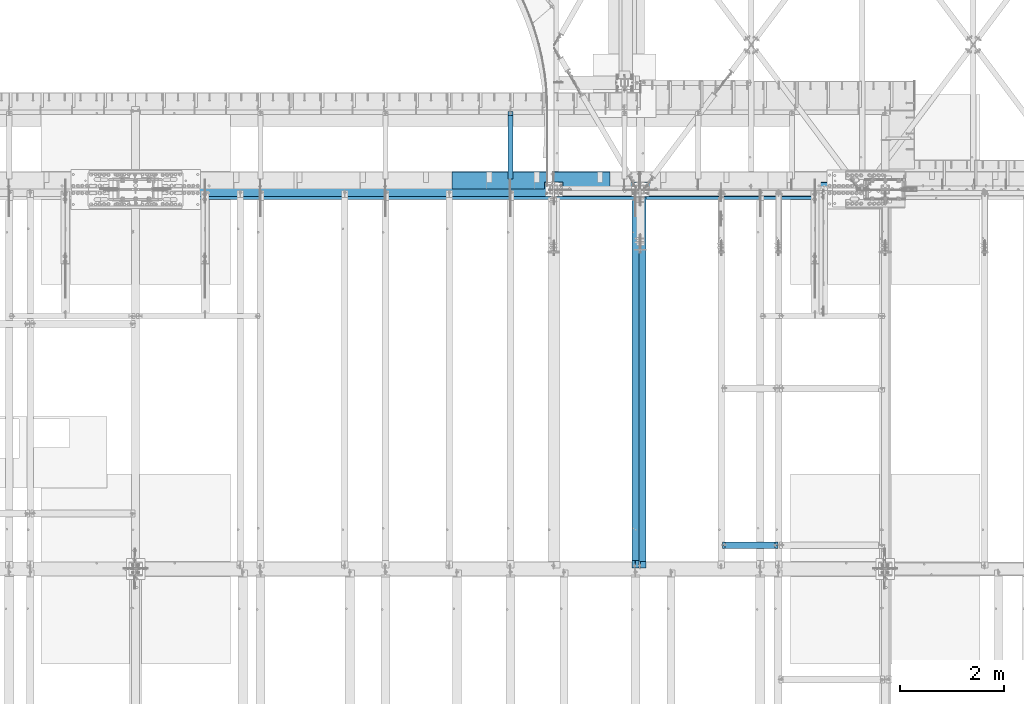
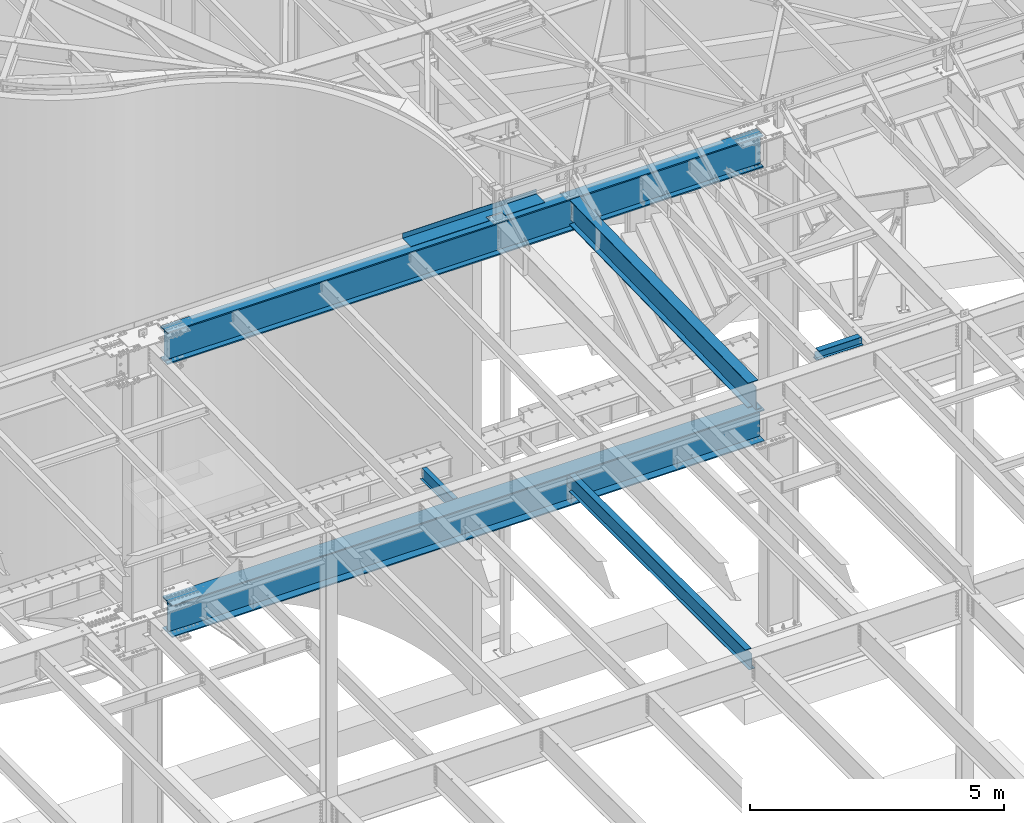
# One storey, part 1142 of 1763: 7 beams, 6 elements without a shape of their own.
"""IFC2X3 building model written with IfcOpenShell, lengths in millimetres."""

from ifc_helpers import new_model, si_unit, frame, origin_with_axes, place, context, subcontext, project, spatial, faceted_brep, material, type_object, element, aggregate, save


model = new_model("IFC2X3")

# Units and contexts
model_context = context("Model", 3, precision=1e-05, world=origin_with_axes())
body_context = subcontext(model_context, "Body", "Model", "MODEL_VIEW")
ifc_project = project(units=[si_unit("LENGTHUNIT", "METRE", prefix="MILLI"), si_unit("AREAUNIT", "SQUARE_METRE"), si_unit("VOLUMEUNIT", "CUBIC_METRE"), si_unit("MASSUNIT", "GRAM", prefix="KILO"), si_unit("TIMEUNIT", "SECOND"), si_unit("PLANEANGLEUNIT", "RADIAN"), si_unit("SOLIDANGLEUNIT", "STERADIAN"), si_unit("THERMODYNAMICTEMPERATUREUNIT", "DEGREE_CELSIUS"), si_unit("LUMINOUSINTENSITYUNIT", "LUMEN")], contexts=[model_context])

# Site, building, storey
site_placement = place(None, origin_with_axes())
site = spatial("IfcSite", under=ifc_project, at=site_placement, CompositionType="ELEMENT")
building_placement = place(site_placement, origin_with_axes())
building = spatial("IfcBuilding", under=site, at=building_placement, Name="Undefined", CompositionType="ELEMENT")
storey_placement = place(building_placement, origin_with_axes())
storey = spatial("IfcBuildingStorey", under=building, at=storey_placement, Name="Undefined", CompositionType="ELEMENT", Elevation=0.0)

# Assembly, beam
assembly_1_placement = place(storey_placement, origin_with_axes())
assembly_1 = element("IfcElementAssembly", 1, at=assembly_1_placement, inside=storey, Name="BEAM", AssemblyPlace="NOTDEFINED", PredefinedType="RIGID_FRAME")
ifc_material_1 = material(Name="STEEL/A992")
beam_type_1 = type_object("IfcBeamType", Name="W8X18", PredefinedType="NOTDEFINED")
beam_1_placement = place(assembly_1_placement, frame((-38107.8885203322, 45262.8, 11502.4228391437), z_axis=(0.0, 0.0, 1.0), x_axis=(1.0, 0.0, 0.0)))
beam_1 = element("IfcBeam", 2, at=beam_1_placement, type_object=beam_type_1, material=ifc_material_1, Name="BEAM", ObjectType="W8X18", context=body_context, shape_type="Brep", body=[
    faceted_brep([(1028.83123168945, 66.6750000000029, 95.25), (1028.83123168945, 3.17500000000291, 95.25), (73.0250000000015, 3.17500000000291, 95.25), (73.0250000000015, 66.6750000000029, 95.25), (15.8750019335712, -66.675000000032, -95.25), (15.8750019335712, -66.675000000032, -103.1875), (1085.98123168945, -66.6750000000029, -103.1875), (1085.98123168945, -66.6750000000029, -95.25), (15.875, -6.52466826784075, -103.1875), (15.875, 61.6753289071276, -103.1875), (15.8749980664215, 66.6749999999665, -103.1875), (1085.98123168945, 66.6750000000029, -103.1875), (1085.98123168945, 6.52466830228514, -103.1875), (1085.98123168945, -61.6753288726832, -103.1875), (15.8749980664215, 66.6749999999665, -95.25), (1085.98123168945, 66.6750000000029, -95.25), (15.875, 61.6746711106171, -95.25), (15.8749999079228, 3.17499999996653, -95.25), (1085.98123168945, 3.17500000000291, -95.25), (1085.98123168945, 6.52532609878836, -95.25), (65.1850797087827, -3.17500000000291, 72.1442315987078), (65.1850797087827, 3.17500000000291, 72.1442315987078), (60.3250001907363, 3.17500000000291, 71.1775016761203), (60.3250001907363, -3.17500000000291, 71.1775016761203), (69.3052561769364, -3.17500000000291, 74.8972454991854), (69.3052561769364, 3.17500000000291, 74.8972454991854), (72.0582700774103, -3.17500000000291, 79.017421967339), (72.0582700774103, 3.17500000000291, 79.017421967339), (73.0250000000015, -3.17500000000291, 83.8775014853854), (73.0250000000015, 3.17500000000291, 83.8775014853854), (1028.83123168945, 3.17500000000291, 83.8775014869243), (1029.79796161204, 3.17500000000291, 79.0174219688779), (1032.55097551252, 3.17500000000291, 74.8972455007242), (1036.67115198067, 3.17500000000291, 72.1442316002467), (1041.53123149872, 3.17500000000291, 71.1775016776592), (1085.98123168945, 3.17500000000291, 71.1775016776592), (1085.98123168945, 3.17500000000291, -91.3182885805927), (15.875, 3.17500000000291, -91.317762344921), (15.875, 3.17500000000291, 71.1775016761203), (15.875, -3.17500000000291, 71.1775016761203), (15.875, -6.52532606434397, -95.25), (15.87500009207, -3.17500000003201, -95.25), (15.875, -3.17500000000291, -91.3182885821243), (1085.98123168945, -3.17500000000291, -95.25), (1085.98123168945, -3.17500000000291, -91.3177623433876), (1085.98123168945, -3.17500000000291, 71.1775016776592), (1041.53123149872, -3.17500000000291, 71.1775016776592), (1036.67115198067, -3.17500000000291, 72.1442316002467), (1032.55097551252, -3.17500000000291, 74.8972455007242), (1029.79796161204, -3.17500000000291, 79.0174219688779), (1028.83123168945, -3.17500000000291, 83.8775014869243), (1028.83123168945, -3.17500000000291, 95.25), (73.0250000000015, -3.17500000000291, 95.25), (1028.83123168945, -66.6750000000029, 103.1875), (1028.83123168945, 66.6750000000029, 103.1875), (73.0250000000015, 66.6750000000029, 103.1875), (73.0250000000015, -66.6750000000029, 103.024323119123), (1028.83123168945, -66.6750000000029, 95.25), (73.0250000000015, -66.6750000000029, 95.25), (1085.98123168945, -61.6746710761727, -95.25)], [[[0, 1, 2, 3]], [[4, 5, 6, 7]], [[5, 8, 9, 10, 11, 12, 13, 6]], [[10, 14, 15, 11]], [[14, 16, 17, 18, 19, 15]], [[20, 21, 22, 23]], [[24, 25, 21, 20]], [[26, 27, 25, 24]], [[28, 29, 27, 26]], [[1, 30, 31, 32, 33, 34, 35, 36, 18, 17, 37, 38, 22, 21, 25, 27, 29, 2]], [[23, 22, 38, 39]], [[37, 17, 16, 14, 10, 9, 8, 5, 4, 40, 41, 42, 39, 38]], [[26, 24, 20, 23, 39, 42, 41, 43, 44, 45, 46, 47, 48, 49, 50, 51, 52, 28]], [[53, 54, 55, 56]], [[57, 53, 56, 58]], [[51, 57, 58, 52]], [[56, 55, 3, 2, 29, 28, 52, 58]], [[54, 0, 3, 55]], [[53, 57, 51, 50, 30, 1, 0, 54]], [[49, 31, 30, 50]], [[48, 32, 31, 49]], [[47, 33, 32, 48]], [[46, 34, 33, 47]], [[45, 35, 34, 46]], [[44, 43, 59, 7, 6, 13, 12, 11, 15, 19, 18, 36, 35, 45]], [[41, 40, 4, 7, 59, 43]]]),
])
aggregate(assembly_1, [beam_1])

assembly_2_placement = place(storey_placement, origin_with_axes())
assembly_2 = element("IfcElementAssembly", 3, at=assembly_2_placement, inside=storey, Name="BEAM", AssemblyPlace="NOTDEFINED", PredefinedType="RIGID_FRAME")
beam_type_2 = type_object("IfcBeamType", Name="W16X26", PredefinedType="NOTDEFINED")
beam_2_placement = place(assembly_2_placement, frame((-39767.3706070317, 44805.6, 4994.275), z_axis=(0.0, 0.0, 1.0), x_axis=(0.0, 1.0, 0.0)))
beam_2 = element("IfcBeam", 4, at=beam_2_placement, type_object=beam_type_2, material=ifc_material_1, Name="BEAM", ObjectType="W16X26", context=body_context, shape_type="Brep", body=[
    faceted_brep([(7104.06248869727, 3.17500000000291, -190.5), (7104.06248869734, 3.17487653380522, -200.025), (7104.06247902929, 69.8499999999985, -200.025), (7104.06247902929, 69.8499999999985, -190.5), (7294.5625, 3.17500000000291, -190.5), (7294.5625, 3.17490415680368, -200.025), (159.543749432261, 3.17500000000291, 190.5), (159.543749432261, 69.8499999999985, 190.5), (7104.0625, 69.8499999999985, 190.5), (7104.0625, 3.17500000000291, 190.5), (159.543749432261, -69.8499999999985, 200.025), (159.543749432261, 69.8499999999985, 200.025), (159.543749432261, 3.17500000000291, 180.715001487732), (159.543749432261, -3.17500000000291, 180.715001487732), (159.543749432261, -3.17500000000291, 190.5), (159.543749432261, -69.8499999999985, 190.5), (158.57701950967, 3.17500000000291, 175.854921969686), (158.57701950967, -3.17500000000291, 175.854921969686), (155.824005609196, 3.17500000000291, 171.734745501532), (155.824005609196, -3.17500000000291, 171.734745501532), (151.703829141043, 3.17500000000291, 168.981731601054), (151.703829141043, -3.17500000000291, 168.981731601054), (146.843749622996, 3.17500000000291, 168.015001678466), (146.843749622996, -3.17500000000291, 168.015001678466), (19.84375, 3.17500000000291, 168.015001678466), (19.84375, -3.17500000000291, 168.015001678466), (19.84375, 3.17500000000291, -190.5), (19.84375, 69.8499999999985, -190.5), (19.84375, 69.8499999999985, -200.025), (19.84375, -69.8499999999985, -200.025), (19.84375, -69.8499999999985, -190.5), (19.84375, -3.17500000000291, -190.5), (7294.5625, -69.8499999999985, -200.025), (7294.5625, -69.8499999999985, -190.5), (7294.5625, -3.17500000000291, -190.5), (7111.90242029122, -3.17500000000291, 156.541729922587), (7107.78224382307, -3.17500000000291, 159.294743823066), (7105.02922992258, -3.17500000000291, 163.414920291219), (7104.0625, -3.17500000000291, 168.274999809265), (7104.0625, -3.17500000000291, 190.5), (7294.5625, -3.17500000000291, 155.575), (7116.76249980927, -3.17500000000291, 155.575), (7104.0625, -69.8499999999985, 190.5), (7104.0625, -69.8499999999985, 200.025), (7104.0625, 69.8499999999985, 200.025), (7104.0625, 3.17500000000291, 168.274999809265), (7105.02922992258, 3.17500000000291, 163.414920291219), (7107.78224382307, 3.17500000000291, 159.294743823066), (7111.90242029122, 3.17500000000291, 156.541729922587), (7116.76249980927, 3.17500000000291, 155.575), (7294.5625, 3.17500000000291, 155.575), (7294.5625, 3.17500000000291, -184.976846570121)], [[[0, 1, 2, 3]], [[4, 5, 1, 0]], [[6, 7, 8, 9]], [[10, 11, 7, 6, 12, 13, 14, 15]], [[13, 12, 16, 17]], [[17, 16, 18, 19]], [[19, 18, 20, 21]], [[21, 20, 22, 23]], [[23, 22, 24, 25]], [[26, 27, 28, 29, 30, 31, 25, 24]], [[30, 29, 32, 33]], [[31, 30, 33, 34]], [[35, 36, 37, 38, 39, 14, 13, 17, 19, 21, 23, 25, 31, 34, 40, 41]], [[15, 14, 39, 42]], [[10, 15, 42, 43]], [[11, 10, 43, 44]], [[7, 11, 44, 8]], [[43, 42, 39, 38, 45, 9, 8, 44]], [[37, 46, 45, 38]], [[36, 47, 46, 37]], [[35, 48, 47, 36]], [[41, 49, 48, 35]], [[40, 50, 49, 41]], [[51, 4, 0, 26, 24, 22, 20, 18, 16, 12, 6, 9, 45, 46, 47, 48, 49, 50]], [[27, 26, 0, 3]], [[28, 27, 3, 2]], [[32, 29, 28, 2, 1, 5]], [[51, 50, 40, 34, 33, 32, 5, 4]]]),
])
aggregate(assembly_2, [beam_2])

assembly_3_placement = place(storey_placement, origin_with_axes())
assembly_3 = element("IfcElementAssembly", 5, at=assembly_3_placement, inside=storey, Name="BEAM", AssemblyPlace="NOTDEFINED", PredefinedType="RIGID_FRAME")
ifc_material_2 = material(Name="STEEL/A36")
beam_type_3 = type_object("IfcBeamType", PredefinedType="NOTDEFINED")
beam_3_placement = place(assembly_3_placement, frame((-41779.2617736983, 52133.5000002128, 11752.2624917654), z_axis=(-1.0, 0.0, 0.0), x_axis=(0.0, 1.0, 0.0)))
beam_3 = element("IfcBeam", 6, at=beam_3_placement, type_object=beam_type_3, material=ifc_material_2, Name="BENT_PLATE", context=body_context, shape_type="Brep", body=[
    faceted_brep([(133.349997685262, -4.76250000000073, -618.523588539611), (133.349999228303, 4.76250000000073, -618.523588539611), (0.0, 4.76250000000073, -618.523588539611), (0.0, -4.76250000000073, -618.523588539611), (133.349997685269, -4.76250000000073, -262.923551918517), (133.34999922831, 4.76250000000073, -262.923551918517), (0.0, -4.76250000000073, -262.923551918517), (0.0, 4.76250000000073, -262.923551918517), (327.024987792967, -4.76250000000073, 1524.00000000001), (327.024987792975, -4.76250000000073, -1524.0), (327.024987792975, -122.237499999999, -1524.0), (327.024987792975, -122.237499999999, 1524.0), (336.549987792969, 4.76250000000073, 1524.0), (0.0, 4.76249999999982, 1524.0), (0.0, -4.76249999999982, 1524.0), (336.549987792969, -122.237499999999, 1524.0), (336.549987792969, 4.76250000000073, -1524.0), (336.549987792969, -122.237499999999, -1524.0), (0.0, -4.76249999999982, -1524.0), (0.0, 4.76249999999982, -1524.0)], [[[0, 1, 2, 3]], [[4, 5, 1, 0]], [[6, 7, 5, 4]], [[8, 9, 10, 11]], [[12, 13, 14, 8, 11, 15]], [[16, 12, 15, 17]], [[11, 10, 17, 15]], [[9, 18, 19, 16, 17, 10]], [[19, 18, 3, 2]], [[13, 12, 16, 19, 2, 1, 5, 7]], [[14, 13, 7, 6]], [[3, 18, 9, 8, 14, 6, 4, 0]]]),
])

assembly_4_placement = place(storey_placement, origin_with_axes())
assembly_4 = element("IfcElementAssembly", 7, at=assembly_4_placement, inside=storey, Name="BEAM", AssemblyPlace="NOTDEFINED", PredefinedType="RIGID_FRAME")
beam_type_4 = type_object("IfcBeamType", Name="W12X16", PredefinedType="NOTDEFINED")
beam_4_placement = place(assembly_4_placement, frame((-42176.1372736983, 52120.8, 5041.9), z_axis=(0.0, 0.0, 1.0), x_axis=(0.0, 1.0, 0.0)))
beam_4 = element("IfcBeam", 8, at=beam_4_placement, type_object=beam_type_4, material=ifc_material_1, Name="BEAM", ObjectType="W12X16", context=body_context, shape_type="Brep", body=[
    faceted_brep([(20.6374999999971, -3.17500000000291, -114.3), (20.6374999999971, 3.17500000000291, -114.3), (192.087500190733, 3.17500000000291, -114.3), (192.087500190733, -3.17500000000291, -114.3), (196.94757970878, 3.17500000000291, -115.266729922588), (196.94757970878, -3.17500000000291, -115.266729922588), (201.067756176933, 3.17500000000291, -118.019743823066), (201.067756176933, -3.17500000000291, -118.019743823066), (203.820770077407, 3.17500000000291, -122.13992029122), (203.820770077407, -3.17500000000291, -122.13992029122), (204.787499999999, -3.17500000000291, -126.999999809265), (204.787499999999, 3.17500000000291, -126.999999809265), (204.787499999999, 3.17500000000291, -146.05), (204.787499999999, 50.8000000000029, -146.05), (204.787499999999, 50.8000000000029, -152.4), (204.787499999999, -50.8000000000029, -152.4), (204.787499999999, -50.8000000000029, -146.05), (204.787499999999, -3.17500000000291, -146.05), (1431.13125000001, 50.8000000000029, 146.05), (1431.13125000001, 3.17500000000291, 146.05), (204.787499999999, 3.17500000000291, 146.05), (204.787499999999, 50.8000000000029, 146.05), (192.087500190733, -3.17500000000291, 114.3), (192.087500190733, 3.17500000000291, 114.3), (20.6374999999971, 3.17500000000291, 114.3), (20.6374999999971, -3.17500000000291, 114.3), (196.94757970878, -3.17500000000291, 115.266729922588), (196.94757970878, 3.17500000000291, 115.266729922588), (201.067756176933, -3.17500000000291, 118.019743823066), (201.067756176933, 3.17500000000291, 118.019743823066), (203.820770077407, -3.17500000000291, 122.13992029122), (203.820770077407, 3.17500000000291, 122.13992029122), (204.787499999999, -3.17500000000291, 126.999999809265), (204.787499999999, 3.17500000000291, 126.999999809265), (1431.13125000001, -50.8000000000029, 152.4), (1431.13125000001, 50.8000000000029, 152.4), (204.787499999999, 50.8000000000029, 152.4), (204.787499999999, -50.8000000000029, 152.4), (1431.13125000001, -50.8000000000029, 146.05), (204.787499999999, -50.8000000000029, 146.05), (1431.13125000001, -3.17500000000291, 146.05), (204.787499999999, -3.17500000000291, 146.05), (1431.13125000001, -3.17500000000291, 139.440001487732), (1431.13125000001, 3.17500000000291, 139.440001487732), (1432.0979799226, -3.17500000000291, 134.579921969686), (1432.0979799226, 3.17500000000291, 134.579921969686), (1434.85099382307, -3.17500000000291, 130.459745501533), (1434.85099382307, 3.17500000000291, 130.459745501533), (1438.97117029122, -3.17500000000291, 127.706731601054), (1438.97117029122, 3.17500000000291, 127.706731601054), (1443.83124980927, -3.17500000000291, 126.740001678467), (1443.83124980927, 3.17500000000291, 126.740001678467), (1507.33125, -3.17500000000291, 126.740001678467), (1507.33125, 3.17500000000291, 126.740001678467), (1507.33125, -3.17500000000291, -146.05), (1507.33125, -50.8000000000029, -146.05), (1507.33125, -50.8000000000029, -152.4), (1507.33125, 50.8000000000029, -152.4), (1507.33125, 50.8000000000029, -146.05), (1507.33125, 3.17500000000291, -146.05)], [[[0, 1, 2, 3]], [[3, 2, 4, 5]], [[5, 4, 6, 7]], [[7, 6, 8, 9]], [[10, 11, 12, 13, 14, 15, 16, 17]], [[9, 8, 11, 10]], [[18, 19, 20, 21]], [[22, 23, 24, 25]], [[26, 27, 23, 22]], [[28, 29, 27, 26]], [[30, 31, 29, 28]], [[32, 33, 31, 30]], [[34, 35, 36, 37]], [[38, 34, 37, 39]], [[40, 38, 39, 41]], [[37, 36, 21, 20, 33, 32, 41, 39]], [[35, 18, 21, 36]], [[34, 38, 40, 42, 43, 19, 18, 35]], [[44, 45, 43, 42]], [[46, 47, 45, 44]], [[48, 49, 47, 46]], [[50, 51, 49, 48]], [[52, 53, 51, 50]], [[54, 55, 56, 57, 58, 59, 53, 52]], [[55, 54, 17, 16]], [[56, 55, 16, 15]], [[57, 56, 15, 14]], [[58, 57, 14, 13]], [[59, 58, 13, 12]], [[6, 4, 2, 1, 24, 23, 27, 29, 31, 33, 20, 19, 43, 45, 47, 49, 51, 53, 59, 12, 11, 8]], [[25, 24, 1, 0]], [[54, 52, 50, 48, 46, 44, 42, 40, 41, 32, 30, 28, 26, 22, 25, 0, 3, 5, 7, 9, 10, 17]]]),
])
aggregate(assembly_4, [beam_4])

assembly_5_placement = place(storey_placement, origin_with_axes())
assembly_5 = element("IfcElementAssembly", 9, at=assembly_5_placement, inside=storey, Name="BEAM", AssemblyPlace="NOTDEFINED", PredefinedType="RIGID_FRAME")
beam_type_5 = type_object("IfcBeamType", Name="W24X76", PredefinedType="NOTDEFINED")
beam_5_placement = place(assembly_5_placement, frame((-39672.2896174484, 44811.8720196671, 11293.0034049879), z_axis=(0.0, -0.0206852279954837, 0.999786037781472), x_axis=(0.0, 0.999786037781472, 0.0206852279954825)))
beam_5 = element("IfcBeam", 10, at=beam_5_placement, type_object=beam_type_5, material=ifc_material_1, Name="BEAM", ObjectType="W24X76", context=body_context, shape_type="Brep", body=[
    faceted_brep([(146.130729189965, 5.85592652185733, -285.749999999822), (146.130729189834, 5.85657638096018, -303.212499999809), (6.50735294029437, 5.8565587883495, -303.21249999977), (6.86864603724098, 5.85590897472866, -285.749999999785), (146.130715525491, 114.300000000003, -285.749999999822), (146.130715525491, 114.300000000003, -303.21249999981), (7170.22949565267, 5.85657652675582, -285.750000001688), (7170.22949565279, 5.85592667387391, -303.212500001675), (7170.22946539726, 114.300000000003, -303.212500001675), (7170.22946539726, 114.300000000003, -285.75000000169), (7260.80121382377, 5.85625000000437, -285.750000001713), (7260.43992072682, 5.85625000000437, -303.2125000017), (7283.57687116025, 5.85625000000437, -285.750000001719), (7283.57687116025, 5.85625000000437, -303.212500001704), (146.130714898274, -5.55625000000146, 264.85250148731), (146.130714898274, 5.55625000000146, 264.85250148731), (145.163984975676, 5.55625000000146, 259.992421969277), (145.163984975676, -5.55625000000146, 259.992421969277), (142.410971075173, 5.55625000000146, 255.872245501134), (142.410971075173, -5.55625000000146, 255.872245501134), (138.290794606983, 5.55625000000146, 253.119231600662), (138.290794606983, -5.55625000000146, 253.119231600662), (133.430715088907, 5.55625000000146, 252.15250167808), (133.430715088907, -5.55625000000146, 252.15250167808), (17.9976631130121, 5.55625000000146, 252.152501678102), (17.9976631130121, -5.55625000000146, 252.152501678102), (6.86864603724098, -5.55625000000146, -285.749999999785), (7283.57687116025, -5.55625000000146, -285.750000001719), (7283.57687116021, -5.55625000000146, 245.802497849256), (7182.92952425702, -5.55625000000146, 245.802497849274), (7178.06944473893, -5.55625000000146, 246.769227771862), (7173.94926827074, -5.55625000000146, 249.522241672334), (7171.19625437024, -5.55625000000146, 253.642418140478), (7170.22952444765, -5.55625000000146, 258.502497658512), (7170.22952444764, -5.55625000000146, 285.749999997881), (146.130714898267, -5.55625000000146, 285.749999999747), (6.86864603724098, -114.300000000003, -285.749999999785), (7170.22952305492, -114.300000000003, -285.75000000169), (7170.22949279905, -5.85592652140622, -285.750000001688), (7283.57687116025, -5.85589489745325, -285.750000001719), (6.50735294029437, -114.300000000003, -303.21249999977), (7170.22952305492, -114.300000000003, -303.212500001677), (7170.22949279918, -5.85657637428812, -303.212500001673), (7283.57687116025, -5.85654475032061, -303.212500001704), (7283.57687116025, 5.55625000000146, -285.750000001719), (7283.57687116021, 5.55625000000146, 245.802497849256), (7182.92952425702, 5.55625000000146, 245.802497849274), (7178.06944473893, 5.55625000000146, 246.769227771862), (7173.94926827074, 5.55625000000146, 249.522241672334), (7171.19625437024, 5.55625000000146, 253.642418140478), (7170.22952444765, 5.55625000000146, 258.502497658512), (7170.22952444764, -114.300000000003, 303.212499997866), (7170.22952444764, -114.300000000003, 285.749999997881), (7170.22952444764, 5.55625000000146, 285.749999997881), (7170.22952444764, 114.300000000003, 285.749999997881), (7170.22952444764, 114.300000000003, 303.212499997866), (146.130714898267, 5.55625000000146, 285.749999999747), (146.130714898267, 114.300000000003, 285.749999999747), (146.130714898267, 114.300000000003, 303.212499999734), (146.130714898267, -114.300000000003, 303.212499999734), (146.130714898267, -114.300000000003, 285.749999999747), (6.86864603724098, 5.55625000000146, -285.749999999785)], [[[0, 1, 2, 3]], [[4, 5, 1, 0]], [[6, 7, 8, 9]], [[10, 11, 7, 6]], [[12, 13, 11, 10]], [[14, 15, 16, 17]], [[17, 16, 18, 19]], [[19, 18, 20, 21]], [[21, 20, 22, 23]], [[23, 22, 24, 25]], [[17, 19, 21, 23, 25, 26, 27, 28, 29, 30, 31, 32, 33, 34, 35, 14]], [[27, 26, 36, 37, 38, 39]], [[36, 40, 41, 37]], [[37, 41, 42, 38]], [[39, 38, 42, 43]], [[13, 12, 44, 45, 28, 27, 39, 43]], [[28, 45, 46, 29]], [[29, 46, 47, 30]], [[30, 47, 48, 31]], [[31, 48, 49, 32]], [[32, 49, 50, 33]], [[51, 52, 34, 33, 50, 53, 54, 55]], [[54, 53, 56, 57]], [[55, 54, 57, 58]], [[51, 55, 58, 59]], [[52, 51, 59, 60]], [[34, 52, 60, 35]], [[59, 58, 57, 56, 15, 14, 35, 60]], [[53, 50, 49, 48, 47, 46, 45, 44, 61, 24, 22, 20, 18, 16, 15, 56]], [[40, 36, 26, 25, 24, 61, 3, 2]], [[8, 7, 11, 13, 43, 42, 41, 40, 2, 1, 5]], [[9, 8, 5, 4]], [[61, 44, 12, 10, 6, 9, 4, 0, 3]]]),
])
aggregate(assembly_5, [beam_5])

assembly_6_placement = place(storey_placement, origin_with_axes())
assembly_6 = element("IfcElementAssembly", 11, at=assembly_6_placement, inside=storey, Name="BEAM", AssemblyPlace="NOTDEFINED", PredefinedType="RIGID_FRAME")
beam_type_6 = type_object("IfcBeamType", Name="W30X173", PredefinedType="NOTDEFINED")
beam_6_placement = place(assembly_6_placement, frame((-49402.4372736983, 52120.8, 4806.95), z_axis=(0.0, 0.0, 1.0), x_axis=(1.0, 0.0, 0.0)))
beam_6 = element("IfcBeam", 12, at=beam_6_placement, type_object=beam_type_6, material=ifc_material_1, Name="BEAM", ObjectType="W30X173", context=body_context, shape_type="Brep", body=[
    faceted_brep([(14022.3875, 41.2750003814726, -360.3625), (13884.2750001907, 41.2750003814726, -360.3625), (13884.2750001907, 41.2750003814726, -387.35), (14022.3875, 41.2750003814726, -387.35), (13880.0224304756, 40.4291116719833, -360.3625), (13880.0224304756, 40.4291116719833, -387.35), (13876.4172759499, 38.0202244315442, -360.3625), (13876.4172759499, 38.0202244315442, -387.35), (13874.0083887095, 34.4150699058882, -360.3625), (13874.0083887095, 34.4150699058882, -387.35), (13873.1625, 30.1625001907378, -360.3625), (13873.1625, 30.1625001907378, -387.35), (13874.0083887095, 25.9099304755873, -360.3625), (13874.0083887095, 25.9099304755873, -387.35), (13876.4172759499, 22.3047759499314, -360.3625), (13876.4172759499, 22.3047759499314, -387.35), (13880.0224304756, 19.8958887094923, -360.3625), (13880.0224304756, 19.8958887094923, -387.35), (13884.2750001907, 19.0500000000029, -360.3625), (13884.2750001907, 19.0500000000029, -387.35), (14022.3875, 19.0500000000029, -360.3625), (14022.3875, 19.0500000000029, -387.35), (557.212499999994, 190.5, -387.35), (557.212499999994, 190.5, -360.3625), (14022.3875, 190.5, -360.3625), (14022.3875, 190.5, -387.35), (557.212499999994, 41.2750003814726, -387.35), (557.212499999994, 41.2750003814726, -360.3625), (695.324999809258, 41.2750003814726, -387.35), (695.324999809258, 41.2750003814726, -360.3625), (699.577569524408, 40.4291116719833, -387.35), (699.577569524408, 40.4291116719833, -360.3625), (703.182724050064, 38.0202244315442, -387.35), (703.182724050064, 38.0202244315442, -360.3625), (705.591611290503, 34.4150699058882, -387.35), (705.591611290503, 34.4150699058882, -360.3625), (706.437499999993, 30.1625001907378, -387.35), (706.437499999993, 30.1625001907378, -360.3625), (705.591611290503, 25.9099304755873, -387.35), (705.591611290503, 25.9099304755873, -360.3625), (703.182724050064, 22.3047759499314, -387.35), (703.182724050064, 22.3047759499314, -360.3625), (699.577569524408, 19.8958887094923, -387.35), (699.577569524408, 19.8958887094923, -360.3625), (695.324999809258, 19.0500000000029, -387.35), (695.324999809258, 19.0500000000029, -360.3625), (557.212499999994, 19.0500000000029, -387.35), (557.212499999994, 19.0500000000029, -360.3625), (557.212499999994, -190.5, -387.35), (557.212499999994, -190.5, -360.3625), (557.212499999994, -7.9375, -360.3625), (557.212499999994, -7.9375, 360.3625), (557.212499999994, -190.5, 360.3625), (557.212499999994, -190.5, 387.35), (557.212499999994, 190.5, 387.35), (557.212499999994, 190.5, 360.3625), (557.212499999994, 7.9375, 360.3625), (557.212499999994, 7.9375, -360.3625), (14022.3875, -190.5, -387.35), (14022.3875, -190.5, -360.3625), (14022.3875, -7.9375, -360.3625), (14022.3875, -7.9375, 360.3625), (14022.3875, -190.5, 360.3625), (14022.3875, -190.5, 387.35), (14022.3875, 190.5, 387.35), (14022.3875, 190.5, 360.3625), (14022.3875, 7.9375, 360.3625), (14022.3875, 7.9375, -360.3625)], [[[0, 1, 2, 3]], [[4, 5, 2, 1]], [[6, 7, 5, 4]], [[8, 9, 7, 6]], [[10, 11, 9, 8]], [[12, 13, 11, 10]], [[14, 15, 13, 12]], [[16, 17, 15, 14]], [[18, 19, 17, 16]], [[20, 21, 19, 18]], [[22, 23, 24, 25]], [[23, 22, 26, 27]], [[27, 26, 28, 29]], [[29, 28, 30, 31]], [[31, 30, 32, 33]], [[33, 32, 34, 35]], [[35, 34, 36, 37]], [[37, 36, 38, 39]], [[39, 38, 40, 41]], [[41, 40, 42, 43]], [[43, 42, 44, 45]], [[45, 44, 46, 47]], [[48, 49, 50, 51, 52, 53, 54, 55, 56, 57, 47, 46]], [[49, 48, 58, 59]], [[50, 49, 59, 60]], [[51, 50, 60, 61]], [[52, 51, 61, 62]], [[53, 52, 62, 63]], [[54, 53, 63, 64]], [[55, 54, 64, 65]], [[56, 55, 65, 66]], [[57, 56, 66, 67]], [[16, 14, 12, 10, 8, 6, 4, 1, 0, 24, 23, 27, 29, 31, 33, 35, 37, 39, 41, 43, 45, 47, 57, 67, 20, 18]], [[25, 24, 0, 3]], [[58, 48, 46, 44, 42, 40, 38, 36, 34, 32, 30, 28, 26, 22, 25, 3, 2, 5, 7, 9, 11, 13, 15, 17, 19, 21]], [[67, 66, 65, 64, 63, 62, 61, 60, 59, 58, 21, 20]]]),
])
aggregate(assembly_6, [beam_6])

# Beam
beam_type_7 = type_object("IfcBeamType", Name="W30X148", PredefinedType="NOTDEFINED")
beam_7_placement = place(assembly_3_placement, frame((-49402.4372736983, 52120.8000002128, 11358.5624917654), z_axis=(0.0, 0.0, 1.0), x_axis=(1.0, 0.0, 0.0)))
beam_7 = element("IfcBeam", 13, at=beam_7_placement, type_object=beam_type_7, material=ifc_material_1, Name="BEAM", ObjectType="W30X148", context=body_context, shape_type="Brep", body=[
    faceted_brep([(14031.9125, -19.0500000000029, -358.775), (13890.6250001907, -19.0500000000029, -358.775), (13890.6250001907, -19.0500000000029, -388.9375), (14031.9125, -19.0500000000029, -388.9375), (13886.3724304756, -19.8958887094923, -358.775), (13886.3724304756, -19.8958887094923, -388.9375), (13882.7672759499, -22.3047759499314, -358.775), (13882.7672759499, -22.3047759499314, -388.9375), (13880.3583887095, -25.9099304755873, -358.775), (13880.3583887095, -25.9099304755873, -388.9375), (13879.5125, -30.1625001907378, -358.775), (13879.5125, -30.1625001907378, -388.9375), (13880.3583887095, -34.4150699058882, -358.775), (13880.3583887095, -34.4150699058882, -388.9375), (13882.7672759499, -38.0202244315442, -358.775), (13882.7672759499, -38.0202244315442, -388.9375), (13886.3724304756, -40.4291116719833, -358.775), (13886.3724304756, -40.4291116719833, -388.9375), (13890.6250001907, -41.2750003814726, -358.775), (13890.6250001907, -41.2750003814726, -388.9375), (14031.9125, -41.2750003814726, -358.775), (14031.9125, -41.2750003814726, -388.9375), (481.012500000012, -7.9375, 358.775), (481.012500000012, -7.9375, -358.775), (14031.9125, -7.9375, -358.775), (14031.9125, -7.9375, 358.775), (481.012500000012, -133.349999999999, 358.775), (14031.9125, -133.349999999999, 358.775), (481.012500000012, -133.349999999999, 388.9375), (14031.9125, -133.349999999999, 388.9375), (481.012500000012, 133.349999999999, 388.9375), (14031.9125, 133.349999999999, 388.9375), (481.012500000012, 133.349999999999, 358.775), (14031.9125, 133.349999999999, 358.775), (481.012500000012, 7.9375, 358.775), (14031.9125, 7.9375, 358.775), (481.012500000012, 7.9375, -358.775), (14031.9125, 7.9375, -358.775), (481.012500000012, 133.349999999999, -358.775), (14031.9125, 133.349999999999, -358.775), (481.012500000012, 133.349999999999, -388.9375), (14031.9125, 133.349999999999, -388.9375), (481.012500000012, -19.0500000000102, -388.9375), (481.012500000012, -19.0500000000102, -358.775), (622.299999809271, -19.0500000000102, -388.9375), (622.299999809271, -19.0500000000102, -358.775), (626.552569524421, -19.8958887094996, -388.9375), (626.552569524421, -19.8958887094996, -358.775), (630.157724050077, -22.3047759499386, -388.9375), (630.157724050077, -22.3047759499386, -358.775), (632.566611290516, -25.9099304755946, -388.9375), (632.566611290516, -25.9099304755946, -358.775), (633.412500000006, -30.162500190745, -388.9375), (633.412500000006, -30.162500190745, -358.775), (632.566611290516, -34.4150699058955, -388.9375), (632.566611290516, -34.4150699058955, -358.775), (630.157724050077, -38.0202244315515, -388.9375), (630.157724050077, -38.0202244315515, -358.775), (626.552569524421, -40.4291116719905, -388.9375), (626.552569524421, -40.4291116719905, -358.775), (622.299999809271, -41.2750003814799, -388.9375), (622.299999809271, -41.2750003814799, -358.775), (481.012500000012, -41.2750003814799, -388.9375), (481.012500000012, -41.2750003814799, -358.775), (481.012500000012, -133.349999999999, -388.9375), (481.012500000012, -133.349999999999, -358.775), (14031.9125, -133.349999999999, -388.9375), (14031.9125, -133.349999999999, -358.775)], [[[0, 1, 2, 3]], [[4, 5, 2, 1]], [[6, 7, 5, 4]], [[8, 9, 7, 6]], [[10, 11, 9, 8]], [[12, 13, 11, 10]], [[14, 15, 13, 12]], [[16, 17, 15, 14]], [[18, 19, 17, 16]], [[20, 21, 19, 18]], [[22, 23, 24, 25]], [[26, 22, 25, 27]], [[28, 26, 27, 29]], [[30, 28, 29, 31]], [[32, 30, 31, 33]], [[34, 32, 33, 35]], [[36, 34, 35, 37]], [[38, 36, 37, 39]], [[40, 38, 39, 41]], [[23, 22, 26, 28, 30, 32, 34, 36, 38, 40, 42, 43]], [[43, 42, 44, 45]], [[45, 44, 46, 47]], [[47, 46, 48, 49]], [[49, 48, 50, 51]], [[51, 50, 52, 53]], [[53, 52, 54, 55]], [[55, 54, 56, 57]], [[57, 56, 58, 59]], [[59, 58, 60, 61]], [[61, 60, 62, 63]], [[64, 65, 63, 62]], [[65, 64, 66, 67]], [[16, 14, 12, 10, 8, 6, 4, 1, 0, 24, 23, 43, 45, 47, 49, 51, 53, 55, 57, 59, 61, 63, 65, 67, 20, 18]], [[41, 39, 37, 35, 33, 31, 29, 27, 25, 24, 0, 3]], [[66, 64, 62, 60, 58, 56, 54, 52, 50, 48, 46, 44, 42, 40, 41, 3, 2, 5, 7, 9, 11, 13, 15, 17, 19, 21]], [[67, 66, 21, 20]]]),
])

aggregate(assembly_3, [beam_3, beam_7])

save(model, "model.ifc")
